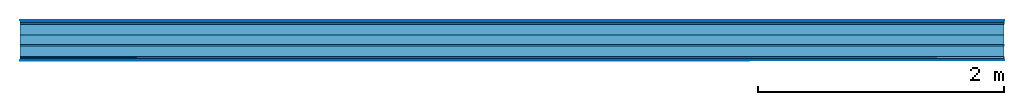
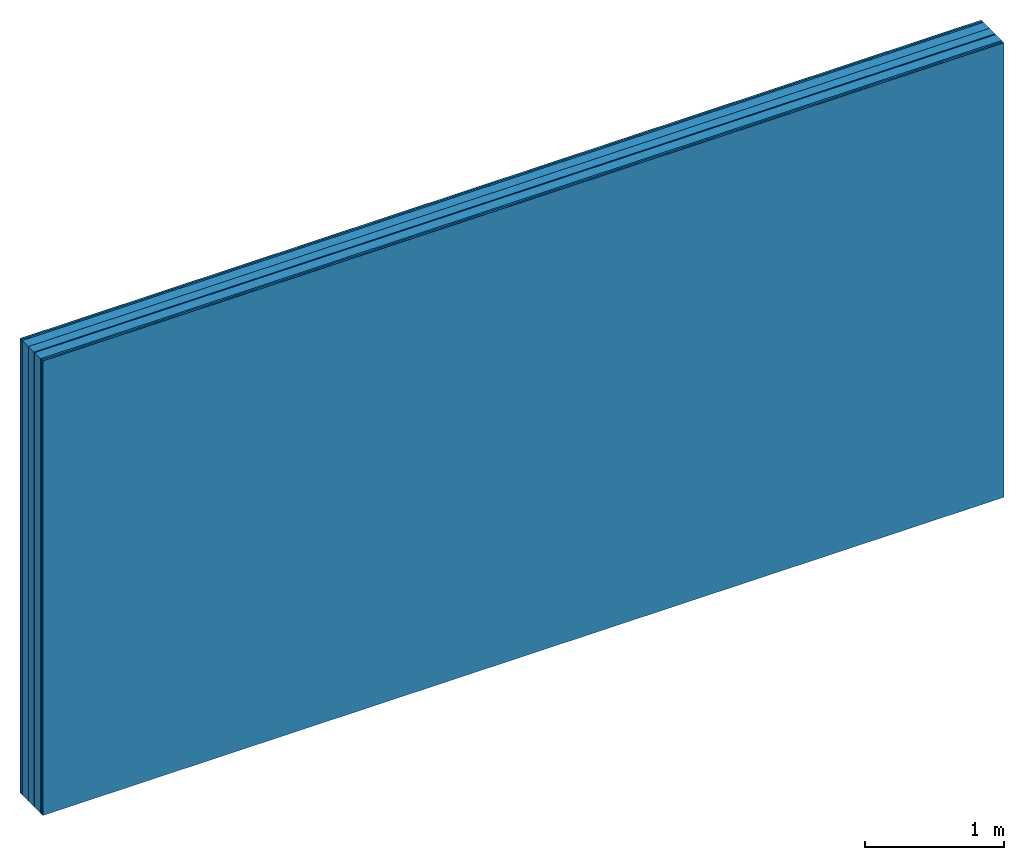
# One storey: 8 plates, 2 members, 1 element without a shape of its own.
"""IFC4 building model written with IfcOpenShell, lengths in metres."""

from ifc_helpers import new_model, si_unit, derived_unit, direction, frame, frame_2d, origin, origin_with_axes, place, context, project, spatial, rectangle, extrude, material, layer, layer_set, type_object, element, aggregate, save


model = new_model("IFC4")

# Units and contexts
plan_context = context("Plan", 3, precision=1e-05, world=origin(), true_north=direction((0.0, 1.0)))
model_context = context("Model", 3, precision=1e-05, world=origin(), true_north=direction((0.0, 1.0)))
ifc_project = project(units=[si_unit("LENGTHUNIT", "METRE"), derived_unit("SOUNDPRESSUREUNIT", [(si_unit("PRESSUREUNIT", "PASCAL", prefix="MICRO"), 0)]), si_unit("ENERGYUNIT", "JOULE", prefix="MEGA"), si_unit("MASSUNIT", "GRAM", prefix="KILO"), derived_unit("THERMALTRANSMITTANCEUNIT", [(si_unit("POWERUNIT", "WATT"), 1), (si_unit("AREAUNIT", "SQUARE_METRE"), -1), (si_unit("THERMODYNAMICTEMPERATUREUNIT", "KELVIN"), -1)]), derived_unit("AREADENSITYUNIT", [(si_unit("MASSUNIT", "GRAM", prefix="KILO"), 1), (si_unit("AREAUNIT", "SQUARE_METRE"), -1)]), derived_unit("USERDEFINED", [(si_unit("ENERGYUNIT", "JOULE", prefix="MEGA"), 1), (si_unit("AREAUNIT", "SQUARE_METRE"), -1)])], contexts=[plan_context, model_context])

# Site, building, storey
site = spatial("IfcSite", under=ifc_project)
building_placement = place(None, origin())
building = spatial("IfcBuilding", under=site, at=building_placement)
storey_placement = place(building_placement, origin())
storey = spatial("IfcBuildingStorey", under=building, at=storey_placement)

# Wall, members, plates
ifc_material_1 = material(Category="04.001")
ifc_layer_1 = layer(ifc_material_1, 0.003, Name="Surface")
ifc_material_2 = material(Name="DFH2IR Knauf Diamant hard- plasterboard", Category="03.007")
ifc_layer_2 = layer(ifc_material_2, 0.015, Name="room side 2nd layer")
ifc_layer_3 = layer(ifc_material_2, 0.015, Name="room side 1st layer")
ifc_material_3 = material(Name="of the art")
ifc_layer_4 = layer(ifc_material_3, 0.0, Name="Bond")
ifc_layer_5 = layer(None, 0.087, Name="Support")
ifc_layer_6 = layer(ifc_material_3, 0.0, Name="Bond")
ifc_material_4 = material(Category="10.008")
ifc_layer_7 = layer(ifc_material_4, 0.08, Name="Intermediate insulation")
ifc_material_5 = material(Name="Air")
ifc_layer_8 = layer(ifc_material_5, 0.01, Name="Air gap")
ifc_layer_9 = layer(ifc_material_3, 0.0, Name="Bond")
ifc_layer_10 = layer(None, 0.087, Name="Support")
ifc_layer_11 = layer(ifc_material_3, 0.0, Name="Bond")
ifc_layer_12 = layer(ifc_material_2, 0.015, Name="room side 1st layer")
ifc_layer_13 = layer(ifc_material_2, 0.015, Name="room side 2nd layer")
ifc_layer_14 = layer(ifc_material_1, 0.003, Name="Surface")
ifc_layer_set = layer_set([ifc_layer_1, ifc_layer_2, ifc_layer_3, ifc_layer_4, ifc_layer_5, ifc_layer_6, ifc_layer_7, ifc_layer_8, ifc_layer_9, ifc_layer_10, ifc_layer_11, ifc_layer_12, ifc_layer_13, ifc_layer_14])
wall_type = type_object("IfcWallType", Name="B0271", PredefinedType="NOTDEFINED", material=ifc_layer_set)
wall_placement = place(None, frame((0.0, 0.0, 0.0), z_axis=(0.0, -1.0, 0.0), x_axis=(1.0, 0.0, 0.0)))
wall = element("IfcWall", 1, at=wall_placement, inside=storey, type_object=wall_type, material=ifc_layer_set, Name="Wall #1")
ifc_material_6 = material(Name="Solid timber panel")
member_1_placement = place(wall_placement, origin())
member_1 = element("IfcMember", 2, at=member_1_placement, material=ifc_material_6, Name="Support", context=plan_context, shape_type="SweptSolid", body=[
    extrude(rectangle(XDim=1.0, YDim=0.087, at=frame_2d((0.5, 0.0435), x_axis=(1.0, 0.0))), frame((0.0, 4.0, 0.033), z_axis=(0.0, -1.0, 0.0), x_axis=(1.0, 0.0, 0.0)), (0.0, 0.0, 1.0), 4.0),
    extrude(rectangle(XDim=1.0, YDim=0.087, at=frame_2d((0.5, 0.0435), x_axis=(1.0, 0.0))), frame((1.0, 4.0, 0.033), z_axis=(0.0, -1.0, 0.0), x_axis=(1.0, 0.0, 0.0)), (0.0, 0.0, 1.0), 4.0),
    extrude(rectangle(XDim=1.0, YDim=0.087, at=frame_2d((0.5, 0.0435), x_axis=(1.0, 0.0))), frame((2.0, 4.0, 0.033), z_axis=(0.0, -1.0, 0.0), x_axis=(1.0, 0.0, 0.0)), (0.0, 0.0, 1.0), 4.0),
    extrude(rectangle(XDim=1.0, YDim=0.087, at=frame_2d((0.5, 0.0435), x_axis=(1.0, 0.0))), frame((3.0, 4.0, 0.033), z_axis=(0.0, -1.0, 0.0), x_axis=(1.0, 0.0, 0.0)), (0.0, 0.0, 1.0), 4.0),
    extrude(rectangle(XDim=1.0, YDim=0.087, at=frame_2d((0.5, 0.0435), x_axis=(1.0, 0.0))), frame((4.0, 4.0, 0.033), z_axis=(0.0, -1.0, 0.0), x_axis=(1.0, 0.0, 0.0)), (0.0, 0.0, 1.0), 4.0),
    extrude(rectangle(XDim=1.0, YDim=0.087, at=frame_2d((0.5, 0.0435), x_axis=(1.0, 0.0))), frame((5.0, 4.0, 0.033), z_axis=(0.0, -1.0, 0.0), x_axis=(1.0, 0.0, 0.0)), (0.0, 0.0, 1.0), 4.0),
    extrude(rectangle(XDim=1.0, YDim=0.087, at=frame_2d((0.5, 0.0435), x_axis=(1.0, 0.0))), frame((6.0, 4.0, 0.033), z_axis=(0.0, -1.0, 0.0), x_axis=(1.0, 0.0, 0.0)), (0.0, 0.0, 1.0), 4.0),
    extrude(rectangle(XDim=1.0, YDim=0.087, at=frame_2d((0.5, 0.0435), x_axis=(1.0, 0.0))), frame((7.0, 4.0, 0.033), z_axis=(0.0, -1.0, 0.0), x_axis=(1.0, 0.0, 0.0)), (0.0, 0.0, 1.0), 4.0),
])
member_2_placement = place(wall_placement, origin())
member_2 = element("IfcMember", 3, at=member_2_placement, material=ifc_material_6, Name="Support", context=plan_context, shape_type="SweptSolid", body=[
    extrude(rectangle(XDim=1.0, YDim=0.087, at=frame_2d((0.5, 0.0435), x_axis=(1.0, 0.0))), frame((0.0, 4.0, 0.21), z_axis=(0.0, -1.0, 0.0), x_axis=(1.0, 0.0, 0.0)), (0.0, 0.0, 1.0), 4.0),
    extrude(rectangle(XDim=1.0, YDim=0.087, at=frame_2d((0.5, 0.0435), x_axis=(1.0, 0.0))), frame((1.0, 4.0, 0.21), z_axis=(0.0, -1.0, 0.0), x_axis=(1.0, 0.0, 0.0)), (0.0, 0.0, 1.0), 4.0),
    extrude(rectangle(XDim=1.0, YDim=0.087, at=frame_2d((0.5, 0.0435), x_axis=(1.0, 0.0))), frame((2.0, 4.0, 0.21), z_axis=(0.0, -1.0, 0.0), x_axis=(1.0, 0.0, 0.0)), (0.0, 0.0, 1.0), 4.0),
    extrude(rectangle(XDim=1.0, YDim=0.087, at=frame_2d((0.5, 0.0435), x_axis=(1.0, 0.0))), frame((3.0, 4.0, 0.21), z_axis=(0.0, -1.0, 0.0), x_axis=(1.0, 0.0, 0.0)), (0.0, 0.0, 1.0), 4.0),
    extrude(rectangle(XDim=1.0, YDim=0.087, at=frame_2d((0.5, 0.0435), x_axis=(1.0, 0.0))), frame((4.0, 4.0, 0.21), z_axis=(0.0, -1.0, 0.0), x_axis=(1.0, 0.0, 0.0)), (0.0, 0.0, 1.0), 4.0),
    extrude(rectangle(XDim=1.0, YDim=0.087, at=frame_2d((0.5, 0.0435), x_axis=(1.0, 0.0))), frame((5.0, 4.0, 0.21), z_axis=(0.0, -1.0, 0.0), x_axis=(1.0, 0.0, 0.0)), (0.0, 0.0, 1.0), 4.0),
    extrude(rectangle(XDim=1.0, YDim=0.087, at=frame_2d((0.5, 0.0435), x_axis=(1.0, 0.0))), frame((6.0, 4.0, 0.21), z_axis=(0.0, -1.0, 0.0), x_axis=(1.0, 0.0, 0.0)), (0.0, 0.0, 1.0), 4.0),
    extrude(rectangle(XDim=1.0, YDim=0.087, at=frame_2d((0.5, 0.0435), x_axis=(1.0, 0.0))), frame((7.0, 4.0, 0.21), z_axis=(0.0, -1.0, 0.0), x_axis=(1.0, 0.0, 0.0)), (0.0, 0.0, 1.0), 4.0),
])
plate_1_placement = place(wall_placement, origin())
plate_1 = element("IfcPlate", 4, at=plate_1_placement, material=ifc_material_1, Name="Surface", context=plan_context, shape_type="SweptSolid", body=[
    extrude(rectangle(XDim=8.0, YDim=4.0, at=frame_2d((4.0, 2.0), x_axis=(1.0, 0.0))), origin_with_axes(), (0.0, 0.0, 1.0), 0.003),
])
plate_2_placement = place(wall_placement, origin())
plate_2 = element("IfcPlate", 5, at=plate_2_placement, material=ifc_material_2, Name="room side 2nd layer", context=plan_context, shape_type="SweptSolid", body=[
    extrude(rectangle(XDim=8.0, YDim=4.0, at=frame_2d((4.0, 2.0), x_axis=(1.0, 0.0))), frame((0.0, 0.0, 0.003), z_axis=(0.0, 0.0, 1.0), x_axis=(1.0, 0.0, 0.0)), (0.0, 0.0, 1.0), 0.015),
])
plate_3_placement = place(wall_placement, origin())
plate_3 = element("IfcPlate", 6, at=plate_3_placement, material=ifc_material_2, Name="room side 1st layer", context=plan_context, shape_type="SweptSolid", body=[
    extrude(rectangle(XDim=8.0, YDim=4.0, at=frame_2d((4.0, 2.0), x_axis=(1.0, 0.0))), frame((0.0, 0.0, 0.018), z_axis=(0.0, 0.0, 1.0), x_axis=(1.0, 0.0, 0.0)), (0.0, 0.0, 1.0), 0.015),
])
plate_4_placement = place(wall_placement, origin())
plate_4 = element("IfcPlate", 7, at=plate_4_placement, material=ifc_material_4, Name="Intermediate insulation", context=plan_context, shape_type="SweptSolid", body=[
    extrude(rectangle(XDim=8.0, YDim=4.0, at=frame_2d((4.0, 2.0), x_axis=(1.0, 0.0))), frame((0.0, 0.0, 0.12), z_axis=(0.0, 0.0, 1.0), x_axis=(1.0, 0.0, 0.0)), (0.0, 0.0, 1.0), 0.08),
])
plate_5_placement = place(wall_placement, origin())
plate_5 = element("IfcPlate", 8, at=plate_5_placement, material=ifc_material_5, Name="Air gap", context=plan_context, shape_type="SweptSolid", body=[
    extrude(rectangle(XDim=8.0, YDim=4.0, at=frame_2d((4.0, 2.0), x_axis=(1.0, 0.0))), frame((0.0, 0.0, 0.2), z_axis=(0.0, 0.0, 1.0), x_axis=(1.0, 0.0, 0.0)), (0.0, 0.0, 1.0), 0.01),
])
plate_6_placement = place(wall_placement, origin())
plate_6 = element("IfcPlate", 9, at=plate_6_placement, material=ifc_material_2, Name="room side 1st layer", context=plan_context, shape_type="SweptSolid", body=[
    extrude(rectangle(XDim=8.0, YDim=4.0, at=frame_2d((4.0, 2.0), x_axis=(1.0, 0.0))), frame((0.0, 0.0, 0.297), z_axis=(0.0, 0.0, 1.0), x_axis=(1.0, 0.0, 0.0)), (0.0, 0.0, 1.0), 0.015),
])
plate_7_placement = place(wall_placement, origin())
plate_7 = element("IfcPlate", 10, at=plate_7_placement, material=ifc_material_2, Name="room side 2nd layer", context=plan_context, shape_type="SweptSolid", body=[
    extrude(rectangle(XDim=8.0, YDim=4.0, at=frame_2d((4.0, 2.0), x_axis=(1.0, 0.0))), frame((0.0, 0.0, 0.312), z_axis=(0.0, 0.0, 1.0), x_axis=(1.0, 0.0, 0.0)), (0.0, 0.0, 1.0), 0.015),
])
plate_8_placement = place(wall_placement, origin())
plate_8 = element("IfcPlate", 11, at=plate_8_placement, material=ifc_material_1, Name="Surface", context=plan_context, shape_type="SweptSolid", body=[
    extrude(rectangle(XDim=8.0, YDim=4.0, at=frame_2d((4.0, 2.0), x_axis=(1.0, 0.0))), frame((0.0, 0.0, 0.327), z_axis=(0.0, 0.0, 1.0), x_axis=(1.0, 0.0, 0.0)), (0.0, 0.0, 1.0), 0.003),
])
aggregate(wall, [plate_1, plate_2, plate_3, member_1, plate_4, plate_5, member_2, plate_6, plate_7, plate_8])

save(model, "model.ifc")
